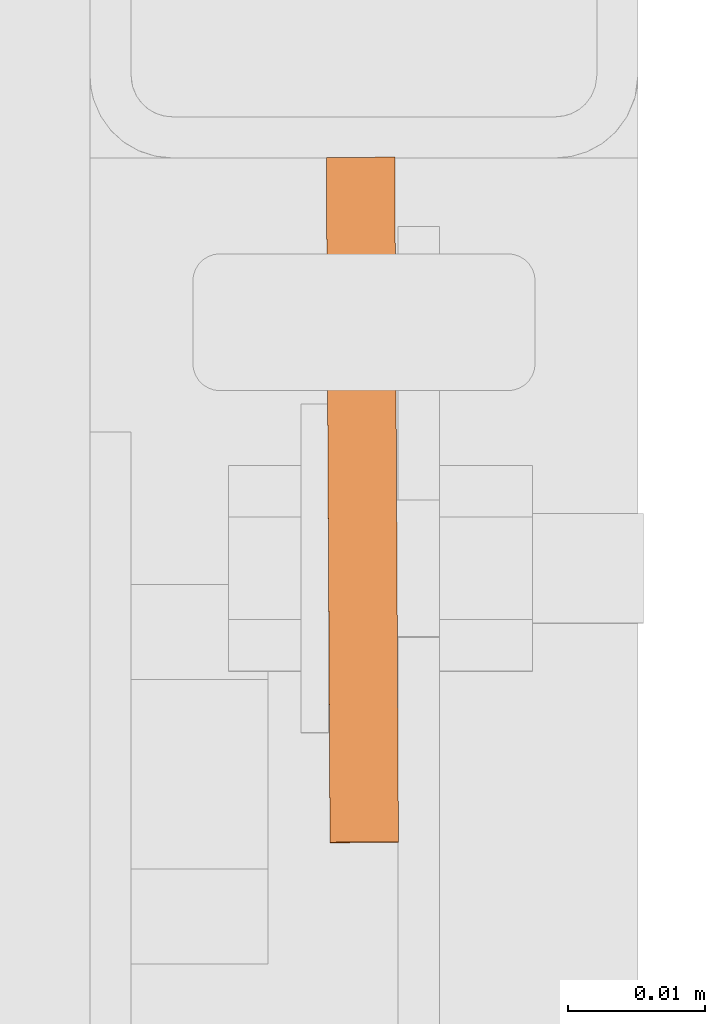
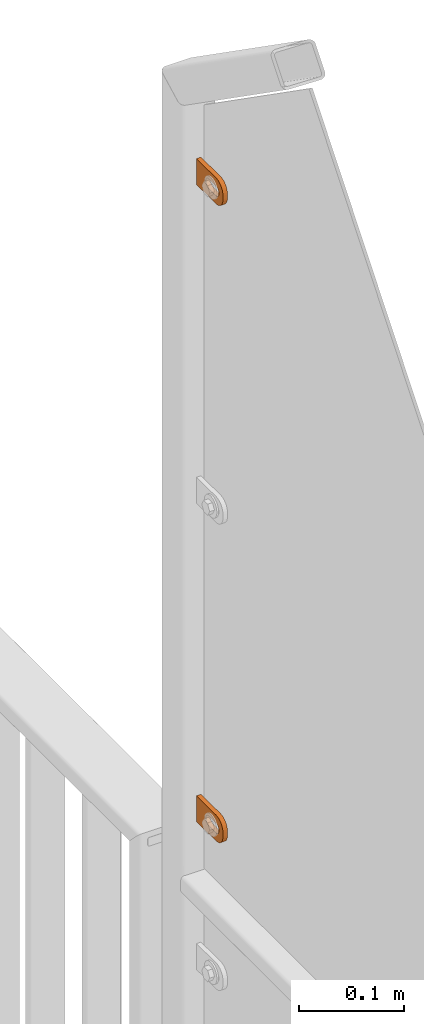
# One storey, part 156 of 156: 2 proxies, 1 element without a shape of its own.
"""IFC2X3 building model written with IfcOpenShell, lengths in millimetres."""

from ifc_helpers import new_model, si_unit, frame, origin_with_axes, place, context, subcontext, project, spatial, faceted_brep, material, type_object, element, aggregate, save


model = new_model("IFC2X3")

# Units and contexts
model_context = context("Model", 3, precision=1e-05, world=origin_with_axes())
body_context = subcontext(model_context, "Body", "Model", "MODEL_VIEW")
ifc_project = project(units=[si_unit("LENGTHUNIT", "METRE", prefix="MILLI"), si_unit("AREAUNIT", "SQUARE_METRE"), si_unit("VOLUMEUNIT", "CUBIC_METRE"), si_unit("MASSUNIT", "GRAM", prefix="KILO"), si_unit("TIMEUNIT", "SECOND"), si_unit("PLANEANGLEUNIT", "RADIAN"), si_unit("SOLIDANGLEUNIT", "STERADIAN"), si_unit("THERMODYNAMICTEMPERATUREUNIT", "DEGREE_CELSIUS"), si_unit("LUMINOUSINTENSITYUNIT", "LUMEN")], contexts=[model_context])

# Site, building, storey
site_placement = place(None, origin_with_axes())
site = spatial("IfcSite", under=ifc_project, at=site_placement, CompositionType="ELEMENT")
building_placement = place(site_placement, origin_with_axes())
building = spatial("IfcBuilding", under=site, at=building_placement, Name="Undefined", CompositionType="ELEMENT")
storey_placement = place(building_placement, origin_with_axes())
storey = spatial("IfcBuildingStorey", under=building, at=storey_placement, Name="Undefined", CompositionType="ELEMENT", Elevation=0.0)

# Assembly, proxies
assembly_placement = place(storey_placement, origin_with_axes())
assembly = element("IfcElementAssembly", 1, at=assembly_placement, inside=storey, AssemblyPlace="NOTDEFINED", PredefinedType="RIGID_FRAME")
ifc_material = material(Name="STEEL/S235JR")
building_element_proxy_type = type_object("IfcBuildingElementProxyType", Name="50", PredefinedType="NOTDEFINED")
proxy_1_placement = place(assembly_placement, frame((46114.7451324463, 20958.0450838797, 4811.41994708695), z_axis=(-0.999985556002151, -0.00537473600001249, 0.0), x_axis=(0.00537473600001187, -0.999985556002151, 1.19999999540802e-08)))
proxy_1 = element("IfcBuildingElementProxy", 2, at=proxy_1_placement, type_object=building_element_proxy_type, material=ifc_material, ObjectType="50", CompositionType="ELEMENT", context=body_context, shape_type="Brep", body=[
    faceted_brep([(37.0000004768226, -5.50000056624776, -2.49999994410609), (23.0000000446889, -5.50000056624594, -2.49999994410973), (23.0000000446889, -5.50000056624594, 2.49999994413156), (37.000000476819, -5.50000056624776, 2.49999994413338), (21.9270028173814, -5.39431966841403, -2.49999994410973), (21.9270028173778, -5.39431966841403, 2.49999994412792), (20.895240828384, -5.0813375413436, -2.49999994411155), (20.895240828384, -5.0813375413436, 2.49999994412974), (19.9443642049955, -4.5730831474084, -2.49999994410973), (19.9443642049919, -4.5730831474084, 2.49999994412792), (19.1109124571012, -3.88908818364325, -2.49999994411155), (19.1109124571012, -3.88908818364325, 2.49999994412792), (18.4269174933361, -3.05563643574806, -2.49999994411155), (18.4269174933361, -3.05563643574806, 2.4999999441261), (17.9186630994009, -2.1047579497108, -2.49999994411155), (17.9186630994009, -2.1047579497108, 2.49999994412428), (17.6056809723377, -1.07299596071425, -2.49999994411337), (17.6056809723341, -1.07299596071425, 2.4999999441261), (17.5000000745022, 3.3527521736687e-07, -2.49999994411519), (17.5000000745058, 3.3527521736687e-07, 2.49999994412428), (17.6056809723377, 1.07299663126287, -2.49999994411701), (17.6056809723377, 1.07299663126287, 2.49999994412428), (17.9186630994154, 2.10475862026124, -2.49999994411701), (17.9186630994118, 2.10475862026124, 2.49999994412246), (18.426917493347, 3.05563617497592, -2.49999994411701), (18.426917493347, 3.05563617497592, 2.49999994412246), (19.1109124571158, 3.88908699154672, -2.49999994411883), (19.1109124571121, 3.88908699154672, 2.49999994412065), (19.9443642050101, 4.57308288663444, -2.49999994411701), (19.9443642050064, 4.57308288663444, 2.49999994412065), (20.8952408283985, 5.08133728056964, -2.49999994411883), (20.8952408283985, 5.08133728056964, 2.49999994412065), (21.9270028173996, 5.39431940764007, -2.49999994411883), (21.927002817396, 5.39431940764007, 2.49999994412065), (23.0000000447108, 5.50000030547199, -2.49999994411883), (23.0000000447071, 5.50000030547199, 2.49999994412246), (37.0000004768408, 5.50000030547017, -2.49999994411519), (37.0000004768408, 5.50000030547017, 2.49999994412428), (38.0729958415031, 5.39431940763825, -2.49999994411519), (38.0729958414995, 5.39431940763825, 2.49999994412428), (39.1047596931458, 5.08133728056691, -2.49999994411337), (39.1047596931421, 5.08133728056691, 2.49999994412428), (40.0556363165415, 4.57308288663171, -2.49999994411519), (40.0556363165379, 4.57308288663171, 2.4999999441261), (40.8890880644285, 3.8890869915449, -2.49999994411337), (40.8890880644285, 3.8890869915449, 2.49999994412792), (41.5730811655449, 3.05563617497228, -2.49999994411337), (41.5730811655449, 3.05563617497228, 2.4999999441261), (42.0813374221252, 2.1047586202576, -2.49999994411155), (42.0813374221252, 2.1047586202576, 2.49999994412792), (42.3943176865469, 1.07299663126014, -2.49999994410973), (42.3943176865469, 1.07299663126014, 2.49999994412974), (42.5000004470239, 3.35271579388063e-07, -2.49999994410973), (42.5000004470276, 3.35271579388063e-07, 2.49999994412974), (42.3943176865469, -1.07299596071698, -2.49999994410791), (42.3943176865432, -1.07299596071698, 2.49999994413156), (42.0813374221179, -2.10475794971444, -2.49999994410791), (42.0813374221143, -2.10475794971444, 2.49999994413338), (41.5730811655376, -3.05563643575169, -2.49999994410791), (41.5730811655339, -3.05563643575169, 2.49999994413156), (40.8890880644176, -3.88908818364507, -2.49999994410609), (40.889088064414, -3.88908818364507, 2.49999994413338), (40.0556363165233, -4.57308314741113, -2.49999994410791), (40.0556363165233, -4.57308314741113, 2.49999994413338), (39.1047596931276, -5.08133754134633, -2.49999994410609), (39.1047596931276, -5.08133754134633, 2.49999994413338), (38.072995841485, -5.39431966841585, -2.49999994410609), (38.072995841485, -5.39431966841585, 2.49999994413156), (37.0000004768044, -14.9999993294514, 2.49999994414065), (39.5361743867034, -14.7502093017147, 2.49999994414065), (41.9748835265273, -14.0104337036646, 2.49999994414065), (44.222414493528, -12.8091058135078, 2.49999994414247), (46.192388981548, -11.1923875659759, 2.49999994413884), (47.809105366443, -9.22241307795593, 2.49999994413884), (49.010433256597, -6.97488397360394, 2.49999994413702), (49.7502088546535, -4.53617483378002, 2.49999994413338), (50.0000007450435, -2.00000092387745, 2.49999994413338), (50.0000007450471, 1.99999973177364, 2.49999994412974), (49.7502088546717, 4.53617457299879, 2.4999999441261), (49.0104332566261, 6.97488464414528, 2.4999999441261), (47.8091053664721, 9.2224128171747, 2.49999994412428), (46.192388981588, 11.1923882365172, 2.49999994412065), (44.2224144935717, 12.8091048542365, 2.49999994411883), (41.9748835265782, 14.0104339085483, 2.49999994411883), (39.5361743867543, 14.7502086334816, 2.49999994411701), (37.0000004768553, 14.9999999999964, 2.49999994411519), (2.91038304567337e-11, 15.0000000000009, 2.49999994410791), (-2.18278728425503e-11, -14.9999993294468, 2.49999994413338), (3.27418092638254e-11, 15.0000000000009, -2.49999994413156), (-2.18278728425503e-11, -14.9999993294468, -2.49999994410791), (37.0000004768008, -14.9999993294514, -2.49999994409882), (39.5361743867034, -14.7502093017147, -2.49999994409882), (41.9748835265309, -14.0104337036646, -2.499999944097), (44.222414493528, -12.8091058135078, -2.49999994409882), (46.1923889815516, -11.1923875659759, -2.49999994409882), (47.8091053664393, -9.22241307795593, -2.49999994410064), (49.0104332566007, -6.97488397360394, -2.49999994410246), (49.7502088546535, -4.53617483378002, -2.49999994410609), (50.0000007450435, -2.00000092387745, -2.49999994410609), (50.0000007450508, 1.99999973177364, -2.49999994410973), (49.750208854668, 4.53617457299879, -2.49999994411155), (49.0104332566261, 6.97488464414528, -2.49999994411337), (47.8091053664721, 9.2224128171747, -2.49999994411519), (46.1923889815916, 11.1923882365172, -2.49999994411883), (44.2224144935717, 12.8091048542365, -2.49999994411883), (41.9748835265782, 14.0104339085483, -2.49999994412065), (39.5361743867579, 14.7502086334816, -2.49999994412246), (37.000000476859, 14.9999999999964, -2.49999994412428)], [[[0, 1, 2, 3]], [[1, 4, 5, 2]], [[4, 6, 7, 5]], [[6, 8, 9, 7]], [[8, 10, 11, 9]], [[10, 12, 13, 11]], [[12, 14, 15, 13]], [[14, 16, 17, 15]], [[16, 18, 19, 17]], [[18, 20, 21, 19]], [[20, 22, 23, 21]], [[22, 24, 25, 23]], [[24, 26, 27, 25]], [[26, 28, 29, 27]], [[28, 30, 31, 29]], [[30, 32, 33, 31]], [[32, 34, 35, 33]], [[34, 36, 37, 35]], [[36, 38, 39, 37]], [[38, 40, 41, 39]], [[40, 42, 43, 41]], [[42, 44, 45, 43]], [[44, 46, 47, 45]], [[46, 48, 49, 47]], [[48, 50, 51, 49]], [[50, 52, 53, 51]], [[52, 54, 55, 53]], [[54, 56, 57, 55]], [[56, 58, 59, 57]], [[58, 60, 61, 59]], [[60, 62, 63, 61]], [[62, 64, 65, 63]], [[64, 66, 67, 65]], [[66, 0, 3, 67]], [[68, 69, 70, 71, 72, 73, 74, 75, 76, 77, 78, 79, 80, 81, 82, 83, 84, 85, 86, 87], [5, 7, 9, 11, 13, 15, 17, 19, 21, 23, 25, 27, 29, 31, 33, 35, 37, 39, 41, 43, 45, 47, 49, 51, 53, 55, 57, 59, 61, 63, 65, 67, 3, 2]], [[86, 88, 89, 87]], [[87, 89, 90, 68]], [[68, 90, 91, 69]], [[69, 91, 92, 70]], [[70, 92, 93, 71]], [[71, 93, 94, 72]], [[72, 94, 95, 73]], [[73, 95, 96, 74]], [[74, 96, 97, 75]], [[75, 97, 98, 76]], [[76, 98, 99, 77]], [[77, 99, 100, 78]], [[78, 100, 101, 79]], [[79, 101, 102, 80]], [[80, 102, 103, 81]], [[81, 103, 104, 82]], [[82, 104, 105, 83]], [[83, 105, 106, 84]], [[84, 106, 107, 85]], [[85, 107, 88, 86]], [[105, 104, 103, 102, 101, 100, 99, 98, 97, 96, 95, 94, 93, 92, 91, 90, 89, 88, 107, 106], [60, 58, 56, 54, 52, 50, 48, 46, 44, 42, 40, 38, 36, 34, 32, 30, 28, 26, 24, 22, 20, 18, 16, 14, 12, 10, 8, 6, 4, 1, 0, 66, 64, 62]]]),
])
proxy_2_placement = place(assembly_placement, frame((46114.7451324463, 20958.0030556083, 4072.79352643115), z_axis=(-0.999985556002151, -0.00537473600001249, 0.0), x_axis=(0.00537473600001187, -0.999985556002151, 1.19999999540802e-08)))
proxy_2 = element("IfcBuildingElementProxy", 3, at=proxy_2_placement, type_object=building_element_proxy_type, material=ifc_material, ObjectType="50", CompositionType="ELEMENT", context=body_context, shape_type="Brep", body=[
    faceted_brep([(37.0000004768226, -5.50000056624776, -2.49999994410609), (23.0000000446889, -5.50000056624594, -2.49999994410973), (23.0000000446889, -5.50000056624594, 2.49999994413156), (37.000000476819, -5.50000056624776, 2.49999994413338), (21.9270028173814, -5.39431966841403, -2.49999994410973), (21.9270028173778, -5.39431966841403, 2.49999994412792), (20.895240828384, -5.0813375413436, -2.49999994411155), (20.895240828384, -5.0813375413436, 2.49999994412974), (19.9443642049955, -4.5730831474084, -2.49999994410973), (19.9443642049919, -4.5730831474084, 2.49999994412792), (19.1109124571012, -3.88908818364325, -2.49999994411155), (19.1109124571012, -3.88908818364325, 2.49999994412792), (18.4269174933361, -3.05563643574806, -2.49999994411155), (18.4269174933361, -3.05563643574806, 2.4999999441261), (17.9186630994009, -2.1047579497108, -2.49999994411155), (17.9186630994009, -2.1047579497108, 2.49999994412428), (17.6056809723377, -1.07299596071425, -2.49999994411337), (17.6056809723341, -1.07299596071425, 2.4999999441261), (17.5000000745022, 3.3527521736687e-07, -2.49999994411519), (17.5000000745058, 3.3527521736687e-07, 2.49999994412428), (17.6056809723377, 1.07299663126287, -2.49999994411701), (17.6056809723377, 1.07299663126287, 2.49999994412428), (17.9186630994154, 2.10475862026124, -2.49999994411701), (17.9186630994118, 2.10475862026124, 2.49999994412246), (18.426917493347, 3.05563617497592, -2.49999994411701), (18.426917493347, 3.05563617497592, 2.49999994412246), (19.1109124571158, 3.88908699154672, -2.49999994411883), (19.1109124571121, 3.88908699154672, 2.49999994412065), (19.9443642050101, 4.57308288663444, -2.49999994411701), (19.9443642050064, 4.57308288663444, 2.49999994412065), (20.8952408283985, 5.08133728056964, -2.49999994411883), (20.8952408283985, 5.08133728056964, 2.49999994412065), (21.9270028173996, 5.39431940764007, -2.49999994411883), (21.927002817396, 5.39431940764007, 2.49999994412065), (23.0000000447108, 5.50000030547199, -2.49999994411883), (23.0000000447071, 5.50000030547199, 2.49999994412246), (37.0000004768408, 5.50000030547017, -2.49999994411519), (37.0000004768408, 5.50000030547017, 2.49999994412428), (38.0729958415031, 5.39431940763825, -2.49999994411519), (38.0729958414995, 5.39431940763825, 2.49999994412428), (39.1047596931458, 5.08133728056691, -2.49999994411337), (39.1047596931421, 5.08133728056691, 2.49999994412428), (40.0556363165415, 4.57308288663171, -2.49999994411519), (40.0556363165379, 4.57308288663171, 2.4999999441261), (40.8890880644285, 3.8890869915449, -2.49999994411337), (40.8890880644285, 3.8890869915449, 2.49999994412792), (41.5730811655449, 3.05563617497228, -2.49999994411337), (41.5730811655449, 3.05563617497228, 2.4999999441261), (42.0813374221252, 2.1047586202576, -2.49999994411155), (42.0813374221252, 2.1047586202576, 2.49999994412792), (42.3943176865469, 1.07299663126014, -2.49999994410973), (42.3943176865469, 1.07299663126014, 2.49999994412974), (42.5000004470239, 3.35271579388063e-07, -2.49999994410973), (42.5000004470276, 3.35271579388063e-07, 2.49999994412974), (42.3943176865469, -1.07299596071698, -2.49999994410791), (42.3943176865432, -1.07299596071698, 2.49999994413156), (42.0813374221179, -2.10475794971444, -2.49999994410791), (42.0813374221143, -2.10475794971444, 2.49999994413338), (41.5730811655376, -3.05563643575169, -2.49999994410791), (41.5730811655339, -3.05563643575169, 2.49999994413156), (40.8890880644176, -3.88908818364507, -2.49999994410609), (40.889088064414, -3.88908818364507, 2.49999994413338), (40.0556363165233, -4.57308314741113, -2.49999994410791), (40.0556363165233, -4.57308314741113, 2.49999994413338), (39.1047596931276, -5.08133754134633, -2.49999994410609), (39.1047596931276, -5.08133754134633, 2.49999994413338), (38.072995841485, -5.39431966841585, -2.49999994410609), (38.072995841485, -5.39431966841585, 2.49999994413156), (37.0000004768044, -14.9999993294514, 2.49999994414065), (39.5361743867034, -14.7502093017147, 2.49999994414065), (41.9748835265273, -14.0104337036646, 2.49999994414065), (44.222414493528, -12.8091058135078, 2.49999994414247), (46.192388981548, -11.1923875659759, 2.49999994413884), (47.809105366443, -9.22241307795593, 2.49999994413884), (49.010433256597, -6.97488397360394, 2.49999994413702), (49.7502088546535, -4.53617483378002, 2.49999994413338), (50.0000007450435, -2.00000092387745, 2.49999994413338), (50.0000007450471, 1.99999973177364, 2.49999994412974), (49.7502088546717, 4.53617457299879, 2.4999999441261), (49.0104332566261, 6.97488464414528, 2.4999999441261), (47.8091053664721, 9.2224128171747, 2.49999994412428), (46.192388981588, 11.1923882365172, 2.49999994412065), (44.2224144935717, 12.8091048542365, 2.49999994411883), (41.9748835265782, 14.0104339085483, 2.49999994411883), (39.5361743867543, 14.7502086334816, 2.49999994411701), (37.0000004768553, 14.9999999999964, 2.49999994411519), (2.91038304567337e-11, 15.0000000000009, 2.49999994410791), (-2.18278728425503e-11, -14.9999993294468, 2.49999994413338), (3.27418092638254e-11, 15.0000000000009, -2.49999994413156), (-2.18278728425503e-11, -14.9999993294468, -2.49999994410791), (37.0000004768008, -14.9999993294514, -2.49999994409882), (39.5361743867034, -14.7502093017147, -2.49999994409882), (41.9748835265309, -14.0104337036646, -2.499999944097), (44.222414493528, -12.8091058135078, -2.49999994409882), (46.1923889815516, -11.1923875659759, -2.49999994409882), (47.8091053664393, -9.22241307795593, -2.49999994410064), (49.0104332566007, -6.97488397360394, -2.49999994410246), (49.7502088546535, -4.53617483378002, -2.49999994410609), (50.0000007450435, -2.00000092387745, -2.49999994410609), (50.0000007450508, 1.99999973177364, -2.49999994410973), (49.750208854668, 4.53617457299879, -2.49999994411155), (49.0104332566261, 6.97488464414528, -2.49999994411337), (47.8091053664721, 9.2224128171747, -2.49999994411519), (46.1923889815916, 11.1923882365172, -2.49999994411883), (44.2224144935717, 12.8091048542365, -2.49999994411883), (41.9748835265782, 14.0104339085483, -2.49999994412065), (39.5361743867579, 14.7502086334816, -2.49999994412246), (37.000000476859, 14.9999999999964, -2.49999994412428)], [[[0, 1, 2, 3]], [[1, 4, 5, 2]], [[4, 6, 7, 5]], [[6, 8, 9, 7]], [[8, 10, 11, 9]], [[10, 12, 13, 11]], [[12, 14, 15, 13]], [[14, 16, 17, 15]], [[16, 18, 19, 17]], [[18, 20, 21, 19]], [[20, 22, 23, 21]], [[22, 24, 25, 23]], [[24, 26, 27, 25]], [[26, 28, 29, 27]], [[28, 30, 31, 29]], [[30, 32, 33, 31]], [[32, 34, 35, 33]], [[34, 36, 37, 35]], [[36, 38, 39, 37]], [[38, 40, 41, 39]], [[40, 42, 43, 41]], [[42, 44, 45, 43]], [[44, 46, 47, 45]], [[46, 48, 49, 47]], [[48, 50, 51, 49]], [[50, 52, 53, 51]], [[52, 54, 55, 53]], [[54, 56, 57, 55]], [[56, 58, 59, 57]], [[58, 60, 61, 59]], [[60, 62, 63, 61]], [[62, 64, 65, 63]], [[64, 66, 67, 65]], [[66, 0, 3, 67]], [[68, 69, 70, 71, 72, 73, 74, 75, 76, 77, 78, 79, 80, 81, 82, 83, 84, 85, 86, 87], [5, 7, 9, 11, 13, 15, 17, 19, 21, 23, 25, 27, 29, 31, 33, 35, 37, 39, 41, 43, 45, 47, 49, 51, 53, 55, 57, 59, 61, 63, 65, 67, 3, 2]], [[86, 88, 89, 87]], [[87, 89, 90, 68]], [[68, 90, 91, 69]], [[69, 91, 92, 70]], [[70, 92, 93, 71]], [[71, 93, 94, 72]], [[72, 94, 95, 73]], [[73, 95, 96, 74]], [[74, 96, 97, 75]], [[75, 97, 98, 76]], [[76, 98, 99, 77]], [[77, 99, 100, 78]], [[78, 100, 101, 79]], [[79, 101, 102, 80]], [[80, 102, 103, 81]], [[81, 103, 104, 82]], [[82, 104, 105, 83]], [[83, 105, 106, 84]], [[84, 106, 107, 85]], [[85, 107, 88, 86]], [[105, 104, 103, 102, 101, 100, 99, 98, 97, 96, 95, 94, 93, 92, 91, 90, 89, 88, 107, 106], [60, 58, 56, 54, 52, 50, 48, 46, 44, 42, 40, 38, 36, 34, 32, 30, 28, 26, 24, 22, 20, 18, 16, 14, 12, 10, 8, 6, 4, 1, 0, 66, 64, 62]]]),
])
aggregate(assembly, [proxy_1, proxy_2])

save(model, "model.ifc")
